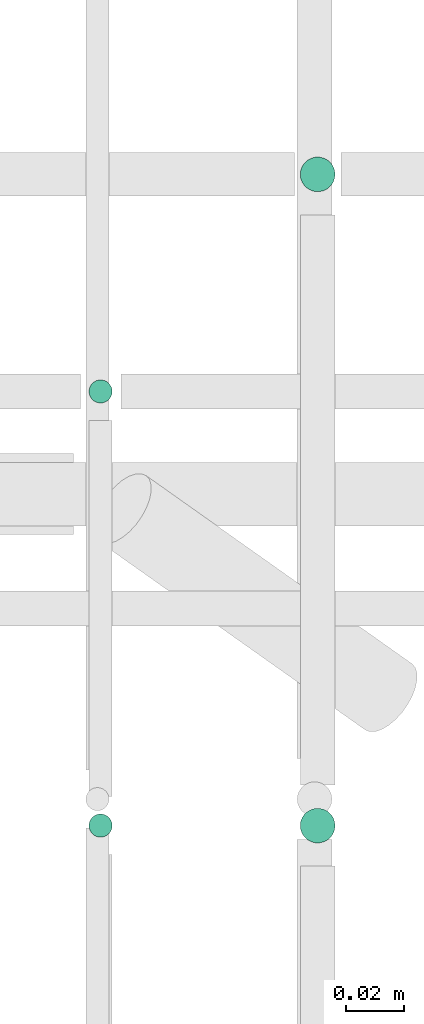
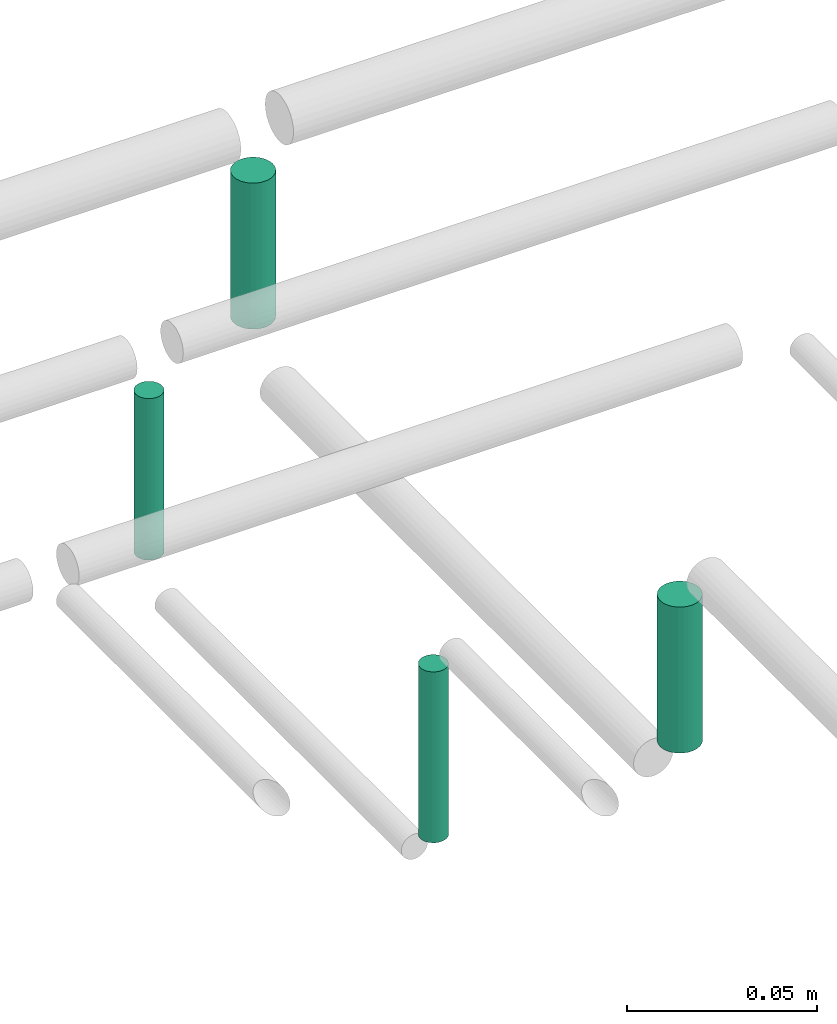
# One storey, part 276 of 331: 4 flow segments.
"""IFC2X3 building model written with IfcOpenShell, lengths in millimetres."""

from ifc_helpers import new_model, entity, si_unit, converted_unit, derived_unit, direction, frame, frame_2d, origin, origin_2d_with_axis, place, context, subcontext, project, spatial, circle, extrude, type_object, element, save


model = new_model("IFC2X3")

# Units and contexts
model_context = context("Model", 3, precision=0.01, world=origin(), true_north=direction((6.12303176911189e-17, 1.0)))
body_context = subcontext(model_context, "Body", "Model", "MODEL_VIEW")
ifc_project = project(units=[si_unit("LENGTHUNIT", "METRE", prefix="MILLI"), si_unit("AREAUNIT", "SQUARE_METRE"), si_unit("VOLUMEUNIT", "CUBIC_METRE"), converted_unit("PLANEANGLEUNIT", "DEGREE", entity("IfcRatioMeasure", 0.0174532925199433), si_unit("PLANEANGLEUNIT", "RADIAN"), dimensions=[0, 0, 0, 0, 0, 0, 0]), si_unit("MASSUNIT", "GRAM", prefix="KILO"), derived_unit("MASSDENSITYUNIT", [(si_unit("MASSUNIT", "GRAM", prefix="KILO"), 1), (si_unit("LENGTHUNIT", "METRE"), -3)]), derived_unit("MOMENTOFINERTIAUNIT", [(si_unit("LENGTHUNIT", "METRE"), 4)]), si_unit("TIMEUNIT", "SECOND"), si_unit("FREQUENCYUNIT", "HERTZ"), si_unit("THERMODYNAMICTEMPERATUREUNIT", "DEGREE_CELSIUS"), derived_unit("THERMALTRANSMITTANCEUNIT", [(si_unit("MASSUNIT", "GRAM", prefix="KILO"), 1), (si_unit("THERMODYNAMICTEMPERATUREUNIT", "KELVIN"), -1), (si_unit("TIMEUNIT", "SECOND"), -3)]), derived_unit("VOLUMETRICFLOWRATEUNIT", [(si_unit("LENGTHUNIT", "METRE"), 3), (si_unit("TIMEUNIT", "SECOND"), -1)]), derived_unit("MASSFLOWRATEUNIT", [(si_unit("MASSUNIT", "GRAM", prefix="KILO"), 1), (si_unit("TIMEUNIT", "SECOND"), -1)]), derived_unit("ROTATIONALFREQUENCYUNIT", [(si_unit("TIMEUNIT", "SECOND"), -1)]), si_unit("ELECTRICCURRENTUNIT", "AMPERE"), si_unit("ELECTRICVOLTAGEUNIT", "VOLT"), si_unit("POWERUNIT", "WATT"), si_unit("FORCEUNIT", "NEWTON", prefix="KILO"), si_unit("ILLUMINANCEUNIT", "LUX"), si_unit("LUMINOUSFLUXUNIT", "LUMEN"), si_unit("LUMINOUSINTENSITYUNIT", "CANDELA"), derived_unit("USERDEFINED", [(si_unit("MASSUNIT", "GRAM", prefix="KILO"), -1), (si_unit("LENGTHUNIT", "METRE"), -2), (si_unit("TIMEUNIT", "SECOND"), 3), (si_unit("LUMINOUSFLUXUNIT", "LUMEN"), 1)]), derived_unit("LINEARVELOCITYUNIT", [(si_unit("LENGTHUNIT", "METRE"), 1), (si_unit("TIMEUNIT", "SECOND"), -1)]), si_unit("PRESSUREUNIT", "PASCAL"), derived_unit("USERDEFINED", [(si_unit("LENGTHUNIT", "METRE"), -2), (si_unit("MASSUNIT", "GRAM", prefix="KILO"), 1), (si_unit("TIMEUNIT", "SECOND"), -2)]), derived_unit("LINEARFORCEUNIT", [(si_unit("MASSUNIT", "GRAM", prefix="KILO"), 1), (si_unit("LENGTHUNIT", "METRE"), 1), (si_unit("TIMEUNIT", "SECOND"), -2), (si_unit("LENGTHUNIT", "METRE"), -1)]), derived_unit("PLANARFORCEUNIT", [(si_unit("MASSUNIT", "GRAM", prefix="KILO"), 1), (si_unit("LENGTHUNIT", "METRE"), 1), (si_unit("TIMEUNIT", "SECOND"), -2), (si_unit("LENGTHUNIT", "METRE"), -2)])], contexts=[model_context])

# Site, building, storey
site_placement = place(None, frame((0.0, -0.00077364408347762, 0.0)))
site = spatial("IfcSite", under=ifc_project, at=site_placement, CompositionType="ELEMENT")
building_placement = place(site_placement, origin())
building = spatial("IfcBuilding", under=site, at=building_placement, CompositionType="ELEMENT")
storey_placement = place(building_placement, origin())
storey = spatial("IfcBuildingStorey", under=building, at=storey_placement, CompositionType="ELEMENT", Elevation=0.0)

# Flow segments
pipe_segment_type = type_object("IfcPipeSegmentType", PredefinedType="NOTDEFINED")
flow_segment_1_placement = place(storey_placement, frame((43540.5132590561, 8075.4146716134, 14485.0)))
element("IfcFlowSegment", 1, at=flow_segment_1_placement, inside=storey, type_object=pipe_segment_type, context=body_context, shape_type="SweptSolid", body=[
    extrude(circle(Radius=4.0, at=origin_2d_with_axis()), frame((5.59527223591499, 5.59527223591607, 0.0), z_axis=(0.0, 0.0, 1.0), x_axis=(-1.0, 0.0, 0.0)), (0.0, 0.0, 1.0), 55.0000000000178),
])
flow_segment_2_placement = place(storey_placement, frame((43613.5132590561, 8073.4146716134, 14489.0)))
element("IfcFlowSegment", 2, at=flow_segment_2_placement, inside=storey, type_object=pipe_segment_type, context=body_context, shape_type="SweptSolid", body=[
    extrude(circle(Radius=6.0, at=origin_2d_with_axis()), frame((7.59527223591454, 7.59527223591562, 0.0), z_axis=(0.0, 0.0, 1.0), x_axis=(-1.0, 0.0, 0.0)), (0.0, 0.0, 1.0), 47.0000000000196),
])
flow_segment_3_placement = place(storey_placement, frame((43540.5132590561, 8225.41467161341, 14485.0)))
element("IfcFlowSegment", 3, at=flow_segment_3_placement, inside=storey, type_object=pipe_segment_type, context=body_context, shape_type="SweptSolid", body=[
    extrude(circle(Radius=4.0, at=frame_2d((0.0, 1.08286712929839e-12), x_axis=(1.0, 0.0))), frame((5.59527223591499, 5.59527223591499, 2.58064562785876e-07)), (0.0, 0.0, 1.0), 51.998923846228),
])
flow_segment_4_placement = place(storey_placement, frame((43613.5132553611, 8298.41467161341, 14489.0)))
element("IfcFlowSegment", 4, at=flow_segment_4_placement, inside=storey, type_object=pipe_segment_type, context=body_context, shape_type="SweptSolid", body=[
    extrude(circle(Radius=6.0, at=origin_2d_with_axis()), frame((7.59527593098637, 7.59527223591562, 4.71716413130707e-07)), (0.0, 0.0, 1.0), 46.9995507361159),
])

save(model, "model.ifc")
